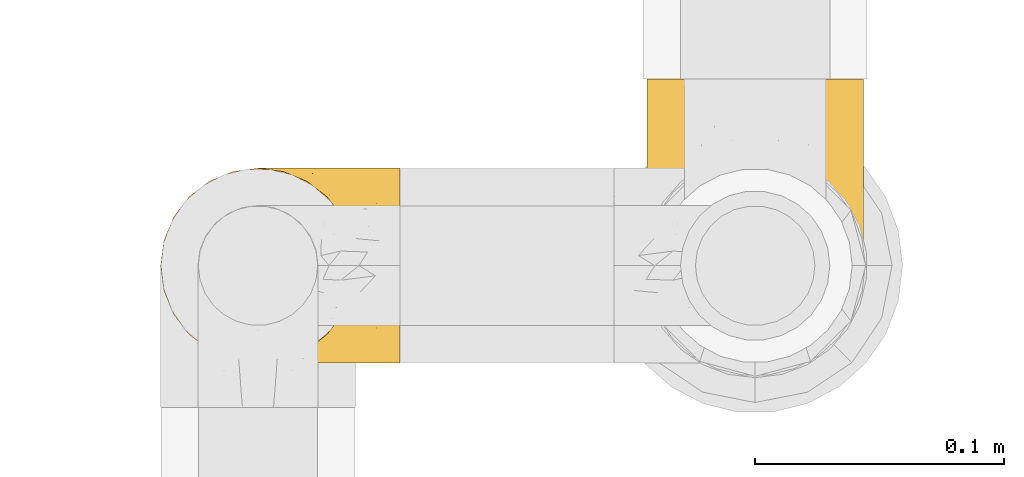
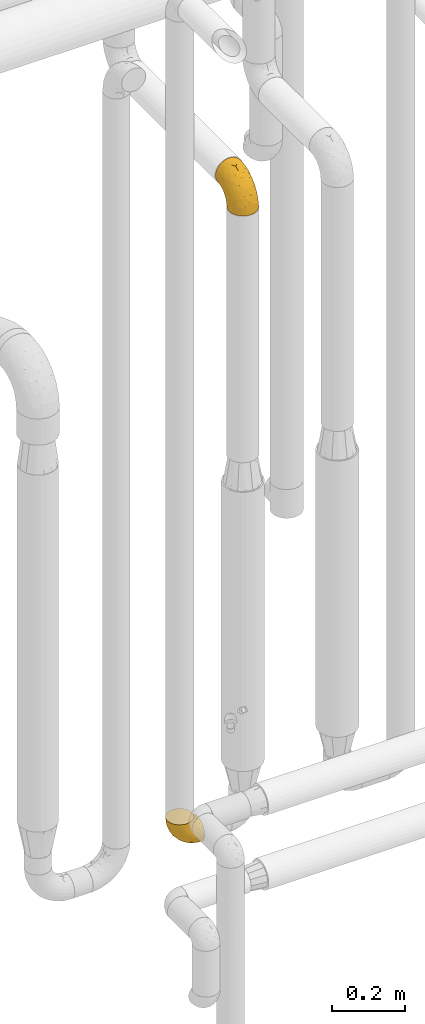
# One storey, part 480 of 827: 2 coverings.
"""IFC2X3 building model written with IfcOpenShell, lengths in millimetres."""

from ifc_helpers import new_model, entity, si_unit, converted_unit, derived_unit, direction, frame, origin, place, context, subcontext, project, spatial, faceted_brep, element, save


model = new_model("IFC2X3")

# Units and contexts
model_context = context("Model", 3, precision=0.01, world=origin(), true_north=direction((6.12303176911189e-17, 1.0)))
body_context = subcontext(model_context, "Body", "Model", "MODEL_VIEW")
ifc_project = project(units=[si_unit("LENGTHUNIT", "METRE", prefix="MILLI"), si_unit("AREAUNIT", "SQUARE_METRE"), si_unit("VOLUMEUNIT", "CUBIC_METRE"), converted_unit("PLANEANGLEUNIT", "DEGREE", entity("IfcRatioMeasure", 0.0174532925199433), si_unit("PLANEANGLEUNIT", "RADIAN"), dimensions=[0, 0, 0, 0, 0, 0, 0]), si_unit("MASSUNIT", "GRAM", prefix="KILO"), derived_unit("MASSDENSITYUNIT", [(si_unit("MASSUNIT", "GRAM", prefix="KILO"), 1), (si_unit("LENGTHUNIT", "METRE"), -3)]), derived_unit("MOMENTOFINERTIAUNIT", [(si_unit("LENGTHUNIT", "METRE"), 4)]), si_unit("TIMEUNIT", "SECOND"), si_unit("FREQUENCYUNIT", "HERTZ"), si_unit("THERMODYNAMICTEMPERATUREUNIT", "DEGREE_CELSIUS"), derived_unit("THERMALTRANSMITTANCEUNIT", [(si_unit("MASSUNIT", "GRAM", prefix="KILO"), 1), (si_unit("THERMODYNAMICTEMPERATUREUNIT", "KELVIN"), -1), (si_unit("TIMEUNIT", "SECOND"), -3)]), derived_unit("VOLUMETRICFLOWRATEUNIT", [(si_unit("LENGTHUNIT", "METRE"), 3), (si_unit("TIMEUNIT", "SECOND"), -1)]), derived_unit("MASSFLOWRATEUNIT", [(si_unit("MASSUNIT", "GRAM", prefix="KILO"), 1), (si_unit("TIMEUNIT", "SECOND"), -1)]), derived_unit("ROTATIONALFREQUENCYUNIT", [(si_unit("TIMEUNIT", "SECOND"), -1)]), si_unit("ELECTRICCURRENTUNIT", "AMPERE"), si_unit("ELECTRICVOLTAGEUNIT", "VOLT"), si_unit("POWERUNIT", "WATT"), si_unit("FORCEUNIT", "NEWTON", prefix="KILO"), si_unit("ILLUMINANCEUNIT", "LUX"), si_unit("LUMINOUSFLUXUNIT", "LUMEN"), si_unit("LUMINOUSINTENSITYUNIT", "CANDELA"), derived_unit("USERDEFINED", [(si_unit("MASSUNIT", "GRAM", prefix="KILO"), -1), (si_unit("LENGTHUNIT", "METRE"), -2), (si_unit("TIMEUNIT", "SECOND"), 3), (si_unit("LUMINOUSFLUXUNIT", "LUMEN"), 1)]), derived_unit("LINEARVELOCITYUNIT", [(si_unit("LENGTHUNIT", "METRE"), 1), (si_unit("TIMEUNIT", "SECOND"), -1)]), si_unit("PRESSUREUNIT", "PASCAL"), derived_unit("USERDEFINED", [(si_unit("LENGTHUNIT", "METRE"), -2), (si_unit("MASSUNIT", "GRAM", prefix="KILO"), 1), (si_unit("TIMEUNIT", "SECOND"), -2)]), derived_unit("LINEARFORCEUNIT", [(si_unit("MASSUNIT", "GRAM", prefix="KILO"), 1), (si_unit("LENGTHUNIT", "METRE"), 1), (si_unit("TIMEUNIT", "SECOND"), -2), (si_unit("LENGTHUNIT", "METRE"), -1)]), derived_unit("PLANARFORCEUNIT", [(si_unit("MASSUNIT", "GRAM", prefix="KILO"), 1), (si_unit("LENGTHUNIT", "METRE"), 1), (si_unit("TIMEUNIT", "SECOND"), -2), (si_unit("LENGTHUNIT", "METRE"), -2)])], contexts=[model_context])

# Site, building, storey
site_placement = place(None, origin())
site = spatial("IfcSite", under=ifc_project, at=site_placement, CompositionType="ELEMENT")
building_placement = place(site_placement, origin())
building = spatial("IfcBuilding", under=site, at=building_placement, CompositionType="ELEMENT")
storey_placement = place(building_placement, frame((0.0, 0.0, 28200.0)))
storey = spatial("IfcBuildingStorey", under=building, at=storey_placement, Name="08", CompositionType="ELEMENT", Elevation=28200.0)

# Coverings
covering_1_placement = place(storey_placement, frame((59252.8, 17454.9, 2425.65)))
element("IfcCovering", 1, at=covering_1_placement, inside=storey, Name=":ADSK_", ObjectType=":ADSK_", PredefinedType="INSULATION", context=body_context, shape_type="Brep", body=[
    faceted_brep([(87.5, 35.41, 1.6), (84.28, 26.21, 1.6), (79.1, 17.97, 1.6), (72.21, 11.08, 1.6), (63.96, 5.9, 1.6), (54.77, 2.68, 1.6), (45.1, 1.6, 1.6), (35.41, 2.69, 1.6), (26.21, 5.91, 1.6), (17.97, 11.09, 1.6), (11.08, 17.98, 1.6), (5.9, 26.23, 1.6), (2.68, 35.42, 1.6), (1.6, 45.1, 1.6), (2.69, 54.78, 1.6), (5.91, 63.98, 1.6), (11.09, 72.22, 1.6), (17.98, 79.11, 1.6), (26.23, 84.29, 1.6), (35.42, 87.51, 1.6), (45.1, 88.6, 1.6), (54.78, 87.5, 1.6), (63.98, 84.28, 1.6), (72.22, 79.1, 1.6), (79.11, 72.21, 1.6), (84.29, 63.96, 1.6), (87.51, 54.77, 1.6), (88.6, 45.1, 1.6), (33.84, 120.1, 34.58), (23.35, 120.1, 38.92), (14.34, 120.1, 45.84), (7.42, 120.1, 54.85), (3.08, 120.1, 65.34), (1.6, 120.1, 76.6), (3.08, 120.1, 87.85), (7.42, 120.1, 98.35), (14.34, 120.1, 107.35), (23.35, 120.1, 114.27), (33.84, 120.1, 118.61), (45.1, 120.1, 120.1), (56.35, 120.1, 118.61), (66.85, 120.1, 114.27), (75.85, 120.1, 107.35), (82.77, 120.1, 98.35), (87.11, 120.1, 87.85), (88.6, 120.1, 76.6), (87.11, 120.1, 65.34), (82.77, 120.1, 54.85), (75.85, 120.1, 45.84), (66.85, 120.1, 38.92), (56.35, 120.1, 34.58), (45.1, 120.1, 33.1), (45.1, 24.23, 71.25), (53.28, 28.38, 75.4), (45.1, 37.33, 84.36), (45.1, 83.48, 114.3), (52.6, 91.73, 115.98), (45.1, 98.7, 116.71), (57.58, 62.13, 102.85), (59.88, 38.14, 83.56), (69.24, 49.82, 87.75), (60.43, 91.17, 113.63), (68.81, 73.3, 102.76), (70.34, 98.13, 109.82), (87.93, 40.2, 22.49), (76.66, 66.33, 91.7), (83.24, 78.94, 88.22), (78.02, 92.75, 101.35), (87.43, 50.64, 50.56), (83.75, 50.37, 66.04), (84.29, 35.59, 42.48), (74.15, 16.62, 30.27), (80.75, 22.51, 23.11), (78.17, 28.43, 49.11), (88.6, 50.8, 30.3), (88.6, 58.93, 42.46), (88.6, 67.06, 54.63), (87.77, 98.53, 82.19), (84.45, 101.45, 93.26), (54.57, 16.09, 56.17), (45.1, 7.4, 38.21), (58.27, 7.16, 30.03), (88.6, 91.39, 70.89), (88.6, 100.45, 72.69), (88.6, 109.5, 74.49), (65.5, 17.74, 50.45), (87.12, 70.23, 71.95), (67.1, 9.57, 22.72), (45.1, 4.98, 22.99), (88.6, 47.2, 12.19), (88.6, 49.0, 21.24), (72.36, 22.26, 49.42), (45.1, 50.44, 97.46), (88.6, 79.23, 62.76), (85.37, 30.68, 20.75), (70.02, 31.84, 68.34), (77.16, 44.66, 73.75), (45.1, 66.96, 105.88), (60.82, 24.8, 66.96), (45.1, 15.81, 54.73), (63.67, 89.18, 19.37), (54.47, 90.85, 15.82), (57.47, 97.95, 26.46), (87.68, 93.22, 62.01), (86.95, 105.29, 62.98), (68.41, 93.5, 29.13), (76.85, 87.89, 33.41), (73.01, 85.09, 24.14), (86.27, 72.04, 39.09), (86.79, 81.31, 50.73), (85.11, 67.33, 25.51), (87.07, 65.71, 34.57), (87.67, 60.17, 29.47), (87.03, 87.89, 56.24), (84.58, 97.01, 53.44), (87.68, 56.24, 18.75), (82.05, 109.86, 52.63), (55.91, 107.34, 31.88), (45.1, 104.35, 28.88), (75.43, 105.97, 43.08), (84.96, 64.5, 16.65), (63.64, 112.57, 36.44), (65.99, 103.13, 34.31), (61.43, 86.44, 9.97), (71.75, 81.56, 14.45), (78.33, 74.09, 10.88), (80.64, 99.39, 47.02), (75.34, 96.78, 38.6), (87.95, 53.3, 11.66), (80.97, 74.03, 22.03), (79.89, 79.87, 29.39), (45.1, 91.38, 11.98), (45.1, 92.82, 17.35), (81.72, 90.97, 44.11), (82.95, 81.62, 38.88), (45.1, 98.58, 23.11), (45.1, 109.71, 30.31), (14.76, 105.98, 43.08), (9.55, 99.39, 47.02), (14.86, 96.79, 38.6), (8.47, 90.97, 44.1), (34.28, 107.35, 31.89), (11.88, 74.11, 10.87), (1.6, 49.0, 21.24), (2.51, 56.25, 18.75), (2.24, 53.3, 11.66), (35.73, 90.85, 15.82), (26.54, 89.18, 19.36), (32.73, 97.96, 26.47), (5.09, 67.35, 25.52), (9.23, 74.04, 22.02), (5.24, 64.52, 16.64), (26.56, 112.57, 36.44), (1.6, 100.45, 72.69), (1.6, 109.5, 74.49), (10.31, 79.88, 29.37), (17.2, 85.1, 24.13), (8.14, 109.86, 52.63), (3.24, 105.29, 62.98), (1.6, 91.39, 70.89), (13.35, 87.9, 33.4), (21.8, 93.52, 29.12), (28.78, 86.44, 9.97), (1.6, 58.93, 42.46), (1.6, 67.06, 54.63), (3.93, 72.04, 39.09), (1.6, 47.2, 12.19), (18.45, 81.57, 14.44), (2.51, 93.22, 62.01), (3.16, 87.89, 56.24), (1.6, 79.23, 62.76), (2.52, 60.18, 29.48), (3.4, 81.31, 50.73), (7.25, 81.63, 38.86), (1.6, 50.8, 30.3), (5.61, 97.01, 53.44), (24.2, 103.14, 34.31), (21.38, 73.27, 102.75), (12.17, 92.75, 101.35), (13.52, 66.34, 91.7), (20.94, 49.8, 87.73), (6.95, 78.94, 88.22), (3.07, 70.23, 71.95), (6.43, 50.35, 66.01), (20.16, 31.83, 68.32), (30.3, 38.14, 83.55), (5.74, 101.45, 93.26), (2.42, 98.53, 82.19), (32.62, 62.12, 102.84), (29.76, 91.16, 113.63), (37.59, 91.73, 115.98), (2.76, 50.64, 50.56), (5.9, 35.6, 42.46), (19.86, 98.12, 109.82), (2.26, 40.21, 22.48), (31.91, 7.17, 30.03), (16.03, 16.63, 30.26), (35.61, 16.09, 56.17), (9.44, 22.53, 23.11), (24.68, 17.74, 50.44), (29.36, 24.8, 66.95), (23.08, 9.58, 22.72), (12.01, 28.44, 49.11), (17.82, 22.27, 49.42), (4.82, 30.69, 20.74), (13.01, 44.64, 73.72), (36.9, 28.37, 75.39)], [[[0, 1, 2, 3, 4, 5, 6, 7, 8, 9, 10, 11, 12, 13, 14, 15, 16, 17, 18, 19, 20, 21, 22, 23, 24, 25, 26, 27]], [[28, 29, 30, 31, 32, 33, 34, 35, 36, 37, 38, 39, 40, 41, 42, 43, 44, 45, 46, 47, 48, 49, 50, 51]], [[52, 53, 54]], [[55, 56, 57]], [[58, 59, 60]], [[61, 62, 63]], [[27, 64, 0]], [[65, 66, 67]], [[41, 40, 61]], [[68, 69, 70]], [[67, 43, 42]], [[63, 42, 41]], [[71, 72, 73]], [[72, 2, 1]], [[68, 74, 75, 76]], [[45, 44, 77]], [[43, 78, 44]], [[79, 80, 81]], [[77, 82, 83, 84, 45]], [[79, 81, 85]], [[71, 2, 72]], [[66, 86, 77]], [[4, 81, 5]], [[67, 66, 78]], [[4, 3, 87]], [[81, 88, 5]], [[66, 65, 69]], [[65, 67, 62]], [[62, 60, 65]], [[71, 3, 2]], [[64, 27, 89, 90, 74]], [[91, 71, 73]], [[40, 57, 56]], [[59, 92, 54]], [[86, 76, 93, 82]], [[1, 0, 94]], [[58, 62, 61]], [[60, 95, 96]], [[85, 81, 87]], [[56, 97, 58]], [[63, 67, 42]], [[87, 81, 4]], [[68, 70, 64]], [[64, 94, 0]], [[94, 72, 1]], [[73, 72, 70]], [[69, 73, 70]], [[73, 96, 95]], [[3, 71, 87]], [[85, 87, 71]], [[58, 61, 56]], [[59, 58, 92]], [[76, 86, 68]], [[69, 96, 73]], [[68, 86, 69]], [[66, 69, 86]], [[68, 64, 74]], [[94, 64, 70]], [[98, 79, 85]], [[79, 52, 99, 80]], [[62, 58, 60]], [[69, 65, 96]], [[59, 98, 95]], [[96, 65, 60]], [[61, 63, 41]], [[67, 63, 62]], [[59, 95, 60]], [[95, 85, 91]], [[88, 81, 80]], [[88, 6, 5]], [[72, 94, 70]], [[77, 44, 78]], [[86, 82, 77]], [[40, 39, 57]], [[95, 98, 85]], [[40, 56, 61]], [[67, 78, 43]], [[77, 78, 66]], [[79, 98, 53]], [[95, 91, 73]], [[85, 71, 91]], [[97, 56, 55]], [[97, 92, 58]], [[53, 98, 59]], [[54, 53, 59]], [[79, 53, 52]], [[100, 101, 102]], [[46, 45, 84, 83]], [[103, 104, 82]], [[82, 104, 83]], [[105, 106, 107]], [[108, 109, 76]], [[110, 111, 112]], [[103, 113, 114]], [[112, 74, 115]], [[48, 47, 116]], [[117, 102, 118]], [[49, 48, 119]], [[75, 108, 76]], [[115, 25, 120]], [[49, 121, 50]], [[122, 105, 102]], [[123, 124, 22]], [[115, 74, 90]], [[23, 22, 124]], [[24, 125, 120]], [[119, 126, 127]], [[89, 26, 128]], [[27, 26, 89]], [[120, 110, 112]], [[24, 120, 25]], [[125, 124, 129]], [[130, 107, 106]], [[21, 20, 131]], [[119, 122, 121]], [[129, 107, 130]], [[50, 117, 51]], [[21, 123, 22]], [[101, 131, 132]], [[116, 119, 48]], [[24, 23, 125]], [[126, 114, 133]], [[128, 25, 115]], [[106, 134, 130]], [[133, 114, 113]], [[115, 90, 128]], [[112, 115, 120]], [[120, 129, 110]], [[75, 74, 112]], [[101, 135, 102]], [[131, 101, 21]], [[101, 100, 123]], [[127, 126, 133]], [[118, 136, 51, 117]], [[104, 47, 46]], [[83, 104, 46]], [[116, 104, 114]], [[101, 123, 21]], [[124, 123, 100]], [[102, 117, 122]], [[124, 125, 23]], [[120, 125, 129]], [[133, 134, 106]], [[134, 109, 108]], [[114, 104, 103]], [[93, 76, 109]], [[133, 106, 127]], [[104, 116, 47]], [[116, 114, 126]], [[121, 117, 50]], [[109, 134, 133]], [[130, 108, 129]], [[108, 130, 134]], [[107, 129, 124]], [[124, 100, 107]], [[105, 122, 127]], [[107, 100, 105]], [[102, 105, 100]], [[89, 128, 90]], [[25, 128, 26]], [[82, 93, 103]], [[113, 93, 109]], [[105, 127, 106]], [[122, 119, 127]], [[119, 121, 49]], [[117, 121, 122]], [[93, 113, 103]], [[133, 113, 109]], [[129, 108, 110]], [[111, 110, 108]], [[108, 75, 111]], [[75, 112, 111]], [[135, 101, 132]], [[135, 118, 102]], [[116, 126, 119]], [[30, 29, 137]], [[138, 139, 140]], [[51, 136, 118, 141]], [[142, 17, 16]], [[143, 144, 145]], [[146, 147, 148]], [[149, 150, 151]], [[152, 29, 28]], [[33, 32, 153, 154]], [[150, 155, 156]], [[157, 31, 30]], [[153, 158, 159]], [[29, 152, 137]], [[148, 141, 118]], [[160, 161, 156]], [[148, 135, 146]], [[137, 138, 157]], [[19, 162, 146]], [[163, 164, 165]], [[14, 13, 166]], [[153, 32, 158]], [[147, 162, 167]], [[18, 17, 167]], [[168, 169, 170]], [[167, 150, 156]], [[151, 150, 142]], [[151, 171, 149]], [[151, 16, 15]], [[172, 140, 173]], [[166, 143, 145]], [[144, 143, 174]], [[142, 167, 17]], [[19, 131, 20]], [[144, 171, 151]], [[18, 162, 19]], [[14, 145, 15]], [[140, 139, 160]], [[172, 165, 164]], [[165, 173, 155]], [[171, 144, 174]], [[15, 144, 151]], [[174, 163, 171]], [[165, 171, 163]], [[19, 146, 131]], [[132, 131, 146]], [[161, 148, 147]], [[151, 142, 16]], [[135, 132, 146]], [[158, 32, 31]], [[157, 158, 31]], [[168, 158, 175]], [[167, 162, 18]], [[146, 162, 147]], [[148, 176, 141]], [[167, 142, 150]], [[159, 158, 168]], [[172, 169, 140]], [[172, 164, 170]], [[138, 140, 175]], [[173, 140, 160]], [[137, 157, 30]], [[158, 157, 175]], [[152, 141, 176]], [[51, 141, 28]], [[155, 173, 160]], [[172, 173, 165]], [[155, 160, 156]], [[165, 155, 150]], [[160, 139, 161]], [[147, 167, 156]], [[148, 161, 176]], [[147, 156, 161]], [[15, 145, 144]], [[166, 145, 14]], [[169, 168, 175]], [[170, 159, 168]], [[137, 176, 139]], [[161, 139, 176]], [[141, 152, 28]], [[137, 152, 176]], [[140, 169, 175]], [[170, 169, 172]], [[171, 165, 149]], [[165, 150, 149]], [[148, 118, 135]], [[157, 138, 175]], [[139, 138, 137]], [[177, 178, 179]], [[177, 179, 180]], [[181, 182, 183]], [[184, 185, 180]], [[186, 187, 181]], [[187, 33, 154, 153, 159]], [[177, 188, 189]], [[35, 34, 186]], [[190, 38, 189]], [[191, 192, 183]], [[191, 164, 163, 174]], [[193, 189, 37]], [[37, 189, 38]], [[36, 35, 178]], [[54, 92, 185]], [[35, 186, 178]], [[193, 178, 177]], [[194, 174, 143, 166, 13]], [[194, 191, 174]], [[179, 178, 181]], [[13, 12, 194]], [[8, 7, 195]], [[9, 196, 10]], [[197, 80, 99, 52]], [[195, 7, 88]], [[196, 198, 10]], [[180, 188, 177]], [[199, 197, 200]], [[199, 195, 197]], [[9, 8, 201]], [[192, 198, 202]], [[193, 37, 36]], [[80, 195, 88]], [[182, 159, 170, 164]], [[187, 34, 33]], [[201, 199, 196]], [[184, 202, 203]], [[201, 8, 195]], [[10, 198, 11]], [[12, 11, 204]], [[38, 190, 57]], [[188, 97, 190]], [[202, 198, 196]], [[204, 198, 192]], [[203, 202, 196]], [[183, 202, 205]], [[199, 201, 195]], [[196, 9, 201]], [[206, 54, 185]], [[97, 55, 190]], [[192, 202, 183]], [[182, 164, 191]], [[183, 205, 179]], [[182, 191, 183]], [[204, 194, 12]], [[191, 194, 192]], [[80, 197, 195]], [[206, 185, 200]], [[183, 179, 181]], [[180, 185, 188]], [[179, 205, 180]], [[184, 180, 205]], [[178, 193, 36]], [[189, 193, 177]], [[202, 184, 205]], [[184, 199, 200]], [[7, 6, 88]], [[198, 204, 11]], [[194, 204, 192]], [[159, 182, 187]], [[181, 187, 182]], [[57, 190, 55]], [[57, 39, 38]], [[188, 190, 189]], [[187, 186, 34]], [[178, 186, 181]], [[185, 92, 188]], [[196, 199, 203]], [[184, 203, 199]], [[188, 92, 97]], [[206, 197, 52]], [[184, 200, 185]], [[197, 206, 200]], [[54, 206, 52]]]),
])
covering_2_placement = place(storey_placement, frame((59057.39, 17459.25, 359.25)))
element("IfcCovering", 2, at=covering_2_placement, inside=storey, Name=":ADSK_", ObjectType=":ADSK_", PredefinedType="INSULATION", context=body_context, shape_type="Brep", body=[
    faceted_brep([(97.75, 1.6, 40.75), (97.75, 2.58, 32.03), (97.75, 5.48, 23.75), (97.75, 10.14, 16.33), (97.75, 16.34, 10.13), (97.75, 23.76, 5.47), (97.75, 32.04, 2.58), (97.75, 40.75, 1.6), (97.75, 49.46, 2.58), (97.75, 57.74, 5.48), (97.75, 65.16, 10.14), (97.75, 71.36, 16.34), (97.75, 76.02, 23.76), (97.75, 78.91, 32.04), (97.75, 79.9, 40.75), (97.75, 79.53, 43.94), (97.75, 78.91, 49.46), (97.75, 77.46, 53.6), (97.75, 76.02, 57.74), (97.75, 71.35, 65.16), (97.75, 65.15, 71.36), (97.75, 57.73, 76.02), (97.75, 49.45, 78.91), (97.75, 40.75, 79.9), (97.75, 32.03, 78.91), (97.75, 23.75, 76.02), (97.75, 16.33, 71.35), (97.75, 10.13, 65.15), (97.75, 5.47, 57.73), (97.75, 2.58, 49.45), (97.75, 1.96, 43.94), (68.43, 68.43, 97.75), (60.32, 74.65, 97.75), (50.88, 78.56, 97.75), (47.16, 79.05, 97.75), (43.95, 79.47, 97.75), (40.75, 79.9, 97.75), (30.61, 78.56, 97.75), (21.17, 74.65, 97.75), (13.06, 68.43, 97.75), (6.84, 60.32, 97.75), (2.93, 50.88, 97.75), (1.6, 40.75, 97.75), (2.93, 30.61, 97.75), (6.84, 21.17, 97.75), (13.06, 13.06, 97.75), (21.17, 6.84, 97.75), (30.61, 2.93, 97.75), (40.75, 1.6, 97.75), (47.16, 2.44, 97.75), (50.88, 2.93, 97.75), (60.32, 6.84, 97.75), (68.43, 13.06, 97.75), (74.65, 21.17, 97.75), (78.56, 30.61, 97.75), (79.9, 40.75, 97.75), (78.56, 50.88, 97.75), (74.65, 60.32, 97.75), (30.59, 40.75, 30.59), (41.23, 40.75, 19.96), (31.39, 27.5, 31.39), (19.96, 40.75, 41.23), (6.3, 40.75, 68.03), (5.21, 34.0, 73.86), (4.64, 40.75, 78.49), (15.42, 29.97, 51.06), (15.6, 19.63, 61.05), (6.88, 27.06, 74.96), (10.45, 18.12, 80.64), (80.79, 2.24, 35.94), (39.87, 4.45, 55.44), (25.91, 5.7, 78.19), (28.57, 8.88, 58.08), (35.0, 2.56, 78.4), (18.15, 11.37, 74.65), (74.57, 14.79, 14.61), (80.38, 8.79, 20.05), (59.65, 11.28, 24.25), (59.36, 2.69, 43.81), (75.93, 1.6, 45.08), (71.31, 1.6, 48.17), (66.69, 1.6, 51.26), (62.06, 1.6, 54.35), (57.44, 1.6, 57.44), (46.63, 7.05, 40.25), (74.83, 29.02, 6.22), (45.67, 2.16, 61.23), (54.35, 1.6, 62.06), (51.26, 1.6, 66.69), (48.17, 1.6, 71.31), (45.08, 1.6, 75.93), (54.03, 32.55, 13.08), (58.15, 22.71, 14.98), (80.8, 21.06, 8.5), (78.49, 40.75, 4.64), (31.82, 19.47, 36.67), (43.52, 23.96, 22.97), (94.17, 1.6, 41.46), (90.6, 1.6, 42.17), (83.46, 1.6, 43.59), (47.16, 17.37, 25.24), (64.11, 5.73, 31.25), (81.54, 4.85, 26.96), (38.43, 12.58, 38.0), (25.45, 14.76, 50.65), (13.13, 40.75, 54.63), (68.03, 40.75, 6.3), (43.59, 1.6, 83.46), (42.88, 1.6, 87.03), (42.17, 1.6, 90.6), (54.63, 40.75, 13.13), (73.05, 17.63, 91.79), (69.6, 12.34, 87.2), (51.66, 2.84, 87.5), (63.89, 8.51, 89.79), (57.82, 5.02, 88.45), (59.13, 4.67, 81.77), (52.25, 2.44, 79.81), (54.86, 2.4, 73.84), (79.38, 30.21, 91.84), (82.07, 30.46, 86.62), (85.12, 40.75, 85.12), (82.63, 40.75, 91.15), (89.2, 31.56, 80.84), (86.06, 22.96, 78.96), (81.78, 11.63, 71.38), (81.63, 16.3, 76.81), (76.19, 10.74, 74.29), (90.86, 2.24, 48.29), (85.89, 2.38, 49.97), (76.5, 23.6, 92.85), (92.32, 25.56, 77.55), (70.11, 3.43, 62.05), (69.83, 6.1, 70.85), (65.67, 3.33, 65.52), (76.0, 14.87, 80.71), (68.84, 8.35, 77.97), (91.37, 10.42, 66.14), (76.37, 3.17, 57.01), (83.17, 7.56, 64.57), (85.98, 4.24, 56.53), (79.95, 2.23, 51.07), (81.01, 21.19, 81.85), (91.15, 40.75, 82.63), (88.52, 15.77, 72.53), (75.86, 6.99, 67.69), (77.41, 20.87, 86.44), (64.86, 7.54, 82.44), (60.69, 4.19, 75.97), (62.7, 3.66, 70.39), (76.5, 57.89, 92.85), (73.85, 63.92, 88.99), (94.17, 79.9, 41.46), (90.6, 79.9, 42.17), (83.46, 79.9, 43.59), (89.2, 49.92, 80.84), (86.06, 58.52, 78.97), (92.32, 55.92, 77.55), (88.52, 65.71, 72.54), (43.59, 79.9, 83.46), (42.17, 79.9, 90.6), (41.46, 79.9, 94.17), (69.6, 69.15, 87.2), (64.84, 73.93, 82.6), (64.5, 72.64, 89.34), (52.81, 78.86, 80.74), (59.13, 76.82, 81.77), (54.5, 79.13, 74.04), (45.08, 79.9, 75.93), (51.66, 78.65, 87.5), (79.95, 79.26, 51.07), (71.31, 79.9, 48.17), (76.38, 78.31, 57.03), (76.18, 70.75, 74.31), (76.44, 66.31, 80.61), (81.43, 65.07, 77.09), (79.38, 51.28, 91.84), (70.71, 71.51, 79.19), (82.07, 51.03, 86.62), (91.37, 71.07, 66.15), (81.89, 69.44, 71.84), (85.98, 77.25, 56.55), (83.17, 73.93, 64.59), (70.11, 78.06, 62.05), (85.9, 79.11, 49.99), (75.93, 79.9, 45.08), (62.7, 77.83, 70.39), (61.23, 77.04, 76.36), (75.83, 74.51, 67.71), (69.82, 75.37, 70.92), (58.44, 76.11, 89.33), (81.13, 59.91, 82.04), (66.69, 79.9, 51.26), (77.41, 60.62, 86.44), (65.71, 78.14, 65.56), (54.35, 79.9, 62.06), (57.44, 79.9, 57.44), (62.06, 79.9, 54.35), (48.17, 79.9, 71.31), (51.26, 79.9, 66.69), (45.67, 79.33, 61.23), (18.15, 70.12, 74.65), (25.91, 75.79, 78.19), (28.58, 72.62, 58.07), (38.43, 68.92, 38.01), (46.64, 74.45, 40.25), (59.66, 70.22, 24.26), (47.16, 64.13, 25.25), (59.36, 78.8, 43.81), (35.0, 78.93, 78.4), (5.21, 47.49, 73.86), (6.88, 54.43, 74.96), (39.88, 77.04, 55.45), (64.12, 75.76, 31.26), (10.45, 63.37, 80.64), (15.6, 61.86, 61.05), (31.39, 54.0, 31.39), (31.82, 62.03, 36.69), (80.8, 79.25, 35.95), (74.83, 52.48, 6.22), (74.57, 66.71, 14.62), (54.02, 48.95, 13.09), (80.38, 72.71, 20.06), (15.42, 51.52, 51.06), (43.52, 57.54, 22.97), (58.15, 58.79, 14.99), (80.8, 60.44, 8.51), (25.47, 66.74, 50.64), (81.54, 76.65, 26.97)], [[[0, 1, 2, 3, 4, 5, 6, 7, 8, 9, 10, 11, 12, 13, 14, 15, 16, 17, 18, 19, 20, 21, 22, 23, 24, 25, 26, 27, 28, 29, 30]], [[31, 32, 33, 34, 35, 36, 37, 38, 39, 40, 41, 42, 43, 44, 45, 46, 47, 48, 49, 50, 51, 52, 53, 54, 55, 56, 57]], [[58, 59, 60, 61]], [[62, 63, 64]], [[65, 66, 67]], [[67, 66, 68]], [[69, 1, 0]], [[70, 71, 72]], [[44, 43, 67]], [[47, 71, 73]], [[45, 74, 46]], [[68, 45, 44]], [[75, 76, 77]], [[76, 3, 2]], [[78, 79, 80, 81, 82, 83]], [[48, 47, 73]], [[70, 72, 84]], [[5, 85, 6]], [[86, 83, 87, 88, 89, 90]], [[91, 85, 92]], [[76, 75, 3]], [[71, 46, 74]], [[85, 5, 93]], [[45, 68, 74]], [[5, 4, 93]], [[85, 94, 6]], [[86, 78, 83]], [[60, 95, 65]], [[96, 95, 60]], [[75, 4, 3]], [[69, 0, 97, 98, 99, 79]], [[75, 77, 100]], [[43, 64, 63]], [[101, 102, 69]], [[101, 76, 102]], [[46, 71, 47]], [[95, 103, 104]], [[92, 85, 93]], [[63, 105, 65]], [[92, 75, 100]], [[91, 106, 85]], [[84, 78, 70]], [[67, 68, 44]], [[65, 67, 63]], [[65, 61, 60]], [[4, 75, 93]], [[92, 93, 75]], [[102, 76, 2]], [[77, 76, 101]], [[84, 77, 101]], [[77, 103, 100]], [[72, 71, 74]], [[70, 86, 73]], [[104, 74, 66]], [[84, 72, 103]], [[70, 73, 71]], [[73, 90, 107, 108, 109, 48]], [[79, 78, 69]], [[101, 69, 78]], [[91, 92, 96]], [[91, 59, 110, 106]], [[2, 1, 102]], [[69, 102, 1]], [[94, 85, 106]], [[94, 7, 6]], [[74, 68, 66]], [[43, 42, 64]], [[43, 63, 67]], [[73, 86, 90]], [[78, 86, 70]], [[95, 100, 103]], [[96, 92, 100]], [[104, 103, 72]], [[65, 95, 66]], [[74, 104, 72]], [[66, 95, 104]], [[95, 96, 100]], [[91, 96, 60]], [[77, 84, 103]], [[78, 84, 101]], [[60, 59, 91]], [[105, 63, 62]], [[105, 61, 65]], [[111, 52, 112]], [[107, 90, 113]], [[114, 115, 116]], [[50, 107, 113]], [[117, 118, 116]], [[54, 119, 55]], [[97, 0, 30, 29, 98]], [[113, 115, 51]], [[120, 121, 122]], [[123, 120, 124]], [[125, 126, 127]], [[128, 28, 129]], [[130, 54, 53]], [[25, 24, 131]], [[132, 133, 134]], [[135, 112, 136]], [[137, 27, 26]], [[121, 120, 123]], [[138, 139, 132]], [[129, 140, 141]], [[135, 126, 142]], [[27, 140, 28]], [[27, 137, 140]], [[49, 48, 109, 108, 107, 50]], [[23, 143, 121, 123]], [[25, 131, 144]], [[26, 25, 144]], [[128, 98, 29]], [[125, 127, 145]], [[146, 130, 111]], [[137, 144, 139]], [[139, 138, 140]], [[116, 147, 114]], [[123, 124, 131]], [[116, 118, 148]], [[134, 83, 82]], [[129, 79, 99]], [[54, 130, 119]], [[141, 79, 129]], [[122, 55, 119]], [[120, 146, 142]], [[117, 113, 90]], [[50, 113, 51]], [[127, 133, 145]], [[147, 136, 112]], [[136, 133, 127]], [[24, 23, 123]], [[118, 117, 89]], [[149, 87, 134]], [[144, 131, 124]], [[24, 123, 131]], [[128, 129, 99]], [[28, 140, 129]], [[144, 137, 26]], [[140, 137, 139]], [[81, 138, 132]], [[138, 80, 141]], [[89, 88, 87, 118]], [[115, 117, 116]], [[140, 138, 141]], [[148, 118, 149]], [[136, 148, 149]], [[147, 116, 148]], [[133, 136, 149]], [[127, 126, 135]], [[136, 147, 148]], [[114, 112, 52]], [[112, 114, 147]], [[51, 114, 52]], [[51, 115, 114]], [[117, 115, 113]], [[117, 90, 89]], [[134, 133, 149]], [[145, 133, 132]], [[132, 139, 145]], [[125, 139, 144]], [[139, 125, 145]], [[126, 144, 124]], [[144, 126, 125]], [[142, 126, 124]], [[120, 142, 124]], [[142, 146, 135]], [[112, 135, 146]], [[136, 127, 135]], [[118, 87, 149]], [[82, 81, 132]], [[111, 130, 53]], [[119, 146, 120]], [[146, 119, 130]], [[122, 119, 120]], [[52, 111, 53]], [[146, 111, 112]], [[134, 82, 132]], [[83, 134, 87]], [[98, 128, 99]], [[80, 138, 81]], [[80, 79, 141]], [[28, 128, 29]], [[150, 151, 57]], [[15, 14, 152, 153, 154, 16]], [[121, 143, 23, 155]], [[150, 57, 56]], [[156, 157, 158]], [[35, 34, 33, 159, 160, 161, 36]], [[162, 31, 57]], [[163, 164, 162]], [[165, 166, 167]], [[155, 23, 22]], [[168, 159, 169]], [[170, 171, 172]], [[173, 174, 175]], [[55, 122, 176]], [[177, 174, 173]], [[22, 157, 155]], [[178, 121, 155]], [[169, 33, 32]], [[20, 19, 179]], [[21, 20, 158]], [[158, 180, 175]], [[181, 182, 179]], [[172, 183, 182]], [[122, 121, 178]], [[181, 19, 18]], [[184, 185, 170]], [[17, 154, 184]], [[186, 187, 177]], [[187, 186, 167]], [[179, 158, 20]], [[21, 157, 22]], [[175, 180, 173]], [[188, 189, 173]], [[164, 166, 190]], [[185, 184, 154]], [[181, 172, 182]], [[156, 191, 178]], [[192, 183, 172]], [[178, 176, 122]], [[193, 150, 176]], [[33, 169, 159]], [[190, 169, 32]], [[189, 194, 186]], [[180, 188, 173]], [[167, 166, 187]], [[166, 164, 163]], [[195, 194, 196]], [[158, 157, 21]], [[155, 157, 156]], [[178, 155, 156]], [[181, 18, 184]], [[17, 16, 154]], [[181, 179, 19]], [[158, 179, 182]], [[170, 181, 184]], [[196, 194, 197]], [[31, 190, 32]], [[165, 190, 166]], [[190, 31, 164]], [[31, 162, 164]], [[177, 163, 162]], [[187, 166, 163]], [[151, 174, 177]], [[177, 173, 189]], [[177, 187, 163]], [[195, 167, 186]], [[165, 198, 168]], [[165, 168, 169]], [[167, 198, 165]], [[190, 165, 169]], [[167, 195, 199, 198]], [[151, 177, 162]], [[175, 191, 156]], [[191, 174, 193]], [[158, 175, 156]], [[174, 191, 175]], [[178, 191, 193]], [[158, 182, 180]], [[188, 182, 183]], [[182, 188, 180]], [[183, 194, 189]], [[183, 189, 188]], [[177, 189, 186]], [[194, 183, 197]], [[176, 150, 56]], [[151, 150, 193]], [[176, 56, 55]], [[193, 176, 178]], [[174, 151, 193]], [[57, 151, 162]], [[183, 192, 197]], [[194, 195, 186]], [[171, 192, 172]], [[172, 181, 170]], [[170, 185, 171]], [[184, 18, 17]], [[200, 168, 198, 199, 195, 196]], [[201, 202, 203]], [[204, 203, 205]], [[204, 206, 207]], [[208, 196, 197, 192, 171, 185]], [[209, 36, 161, 160, 159, 168]], [[202, 38, 37]], [[201, 38, 202]], [[210, 41, 211]], [[200, 208, 212]], [[205, 208, 213]], [[214, 211, 40]], [[40, 211, 41]], [[214, 201, 215]], [[58, 61, 216, 59]], [[201, 39, 38]], [[207, 217, 204]], [[213, 208, 218]], [[218, 185, 154, 153, 152, 14]], [[14, 13, 218]], [[9, 8, 219]], [[10, 220, 11]], [[221, 106, 110, 59]], [[219, 8, 94]], [[220, 222, 11]], [[223, 211, 215]], [[221, 216, 224]], [[225, 219, 221]], [[10, 9, 226]], [[213, 222, 206]], [[226, 9, 219]], [[106, 219, 94]], [[212, 202, 209]], [[201, 203, 227]], [[226, 225, 220]], [[207, 206, 220]], [[214, 40, 39]], [[11, 222, 12]], [[12, 222, 228]], [[41, 210, 64]], [[223, 105, 210]], [[223, 215, 217]], [[105, 62, 210]], [[206, 222, 220]], [[228, 222, 213]], [[207, 220, 225]], [[205, 206, 204]], [[225, 226, 219]], [[220, 10, 226]], [[209, 202, 37]], [[203, 202, 212]], [[205, 203, 212]], [[204, 217, 227]], [[36, 209, 37]], [[209, 168, 200]], [[218, 13, 228]], [[208, 185, 218]], [[106, 221, 219]], [[221, 59, 216]], [[218, 228, 213]], [[13, 12, 228]], [[8, 7, 94]], [[201, 214, 39]], [[211, 214, 215]], [[64, 210, 62]], [[64, 42, 41]], [[223, 210, 211]], [[208, 200, 196]], [[209, 200, 212]], [[225, 224, 207]], [[207, 224, 217]], [[223, 217, 216]], [[204, 227, 203]], [[217, 215, 227]], [[201, 227, 215]], [[221, 224, 225]], [[217, 224, 216]], [[208, 205, 212]], [[206, 205, 213]], [[216, 61, 223]], [[223, 61, 105]]]),
])

save(model, "model.ifc")
